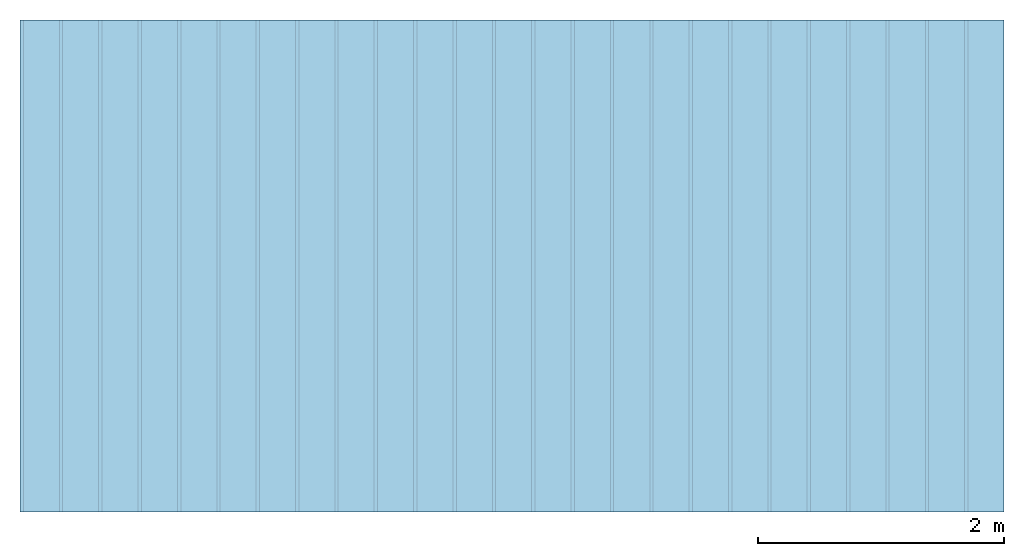
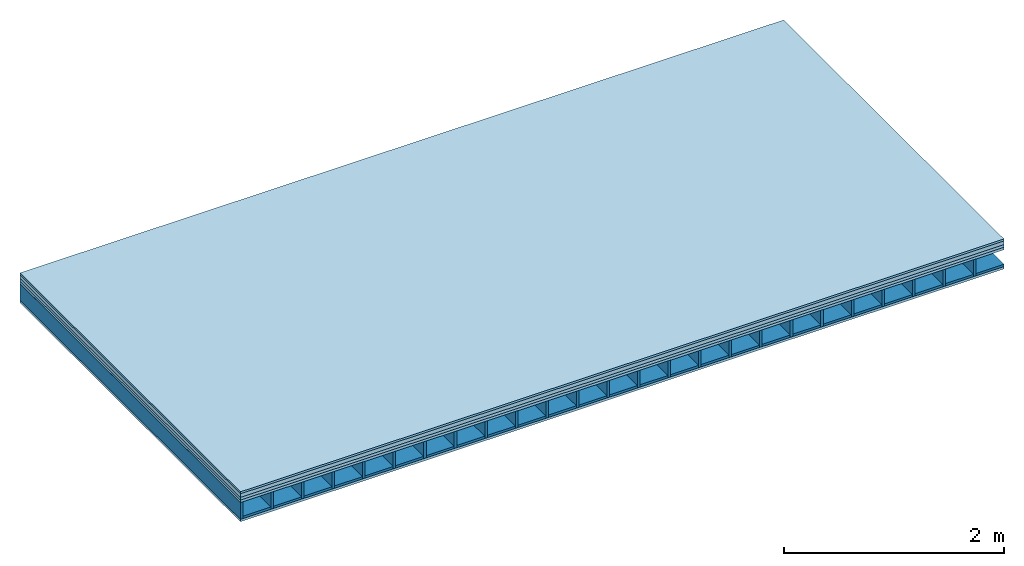
# One storey: 5 plates, 2 members, 1 element without a shape of its own.
"""IFC4 building model written with IfcOpenShell, lengths in metres."""

from ifc_helpers import new_model, si_unit, derived_unit, direction, frame, frame_2d, origin, origin_with_axes, place, context, project, spatial, rectangle, extrude, material, layer, layer_set, type_object, element, aggregate, save


model = new_model("IFC4")

# Units and contexts
plan_context = context("Plan", 3, precision=1e-05, world=origin(), true_north=direction((0.0, 1.0)))
model_context = context("Model", 3, precision=1e-05, world=origin(), true_north=direction((0.0, 1.0)))
ifc_project = project(units=[si_unit("LENGTHUNIT", "METRE"), derived_unit("SOUNDPRESSUREUNIT", [(si_unit("PRESSUREUNIT", "PASCAL", prefix="MICRO"), 0)]), si_unit("ENERGYUNIT", "JOULE", prefix="MEGA"), si_unit("MASSUNIT", "GRAM", prefix="KILO"), derived_unit("THERMALTRANSMITTANCEUNIT", [(si_unit("POWERUNIT", "WATT"), 1), (si_unit("AREAUNIT", "SQUARE_METRE"), -1), (si_unit("THERMODYNAMICTEMPERATUREUNIT", "KELVIN"), -1)]), derived_unit("AREADENSITYUNIT", [(si_unit("MASSUNIT", "GRAM", prefix="KILO"), 1), (si_unit("AREAUNIT", "SQUARE_METRE"), -1)]), derived_unit("USERDEFINED", [(si_unit("ENERGYUNIT", "JOULE", prefix="MEGA"), 1), (si_unit("AREAUNIT", "SQUARE_METRE"), -1)])], contexts=[plan_context, model_context])

# Site, building, storey
site = spatial("IfcSite", under=ifc_project)
building_placement = place(None, origin())
building = spatial("IfcBuilding", under=site, at=building_placement)
storey_placement = place(building_placement, origin())
storey = spatial("IfcBuildingStorey", under=building, at=storey_placement)

# Slab, members, plates
ifc_material_1 = material(Name="OSB/3", Category="07.013")
ifc_layer_1 = layer(ifc_material_1, 0.022, Name="On-material")
ifc_material_2 = material(Name="internal", Category="10.009")
ifc_layer_2 = layer(ifc_material_2, 0.04, Name="Impact sound insulation")
ifc_material_3 = material(Name="with broken")
ifc_layer_3 = layer(ifc_material_3, 0.03, Name="on Supporting structure")
ifc_material_4 = material(Name="3-layer board Spruce Nova Top", Category="07.001")
ifc_layer_4 = layer(ifc_material_4, 0.027, Name="Sub-floor")
ifc_material_5 = material(Name="Rigid, of the art")
ifc_layer_5 = layer(ifc_material_5, 0.0, Name="Bond")
ifc_layer_6 = layer(None, 0.186, Name="Supporting structure")
ifc_layer_7 = layer(ifc_material_5, 0.0, Name="Bond")
ifc_layer_8 = layer(ifc_material_4, 0.027, Name="Lower layer 1")
ifc_layer_set = layer_set([ifc_layer_1, ifc_layer_2, ifc_layer_3, ifc_layer_4, ifc_layer_5, ifc_layer_6, ifc_layer_7, ifc_layer_8])
slab_type = type_object("IfcSlabType", Name="A0016", PredefinedType="NOTDEFINED", material=ifc_layer_set)
slab_placement = place(None, frame((0.0, 0.0, 0.0), z_axis=(0.0, 0.0, -1.0), x_axis=(1.0, 0.0, 0.0)))
slab = element("IfcSlab", 1, at=slab_placement, inside=storey, type_object=slab_type, material=ifc_layer_set, Name="Slab #1")
ifc_material_6 = material()
member_1_placement = place(slab_placement, origin())
member_1 = element("IfcMember", 2, at=member_1_placement, material=ifc_material_6, Name="Supporting structure", context=plan_context, shape_type="SweptSolid", body=[
    extrude(rectangle(XDim=0.027, YDim=0.186, at=frame_2d((0.0135, 0.093), x_axis=(1.0, 0.0))), frame((0.0, 4.0, 0.119), z_axis=(0.0, -1.0, 0.0), x_axis=(1.0, 0.0, 0.0)), (0.0, 0.0, 1.0), 4.0),
    extrude(rectangle(XDim=0.027, YDim=0.186, at=frame_2d((0.0135, 0.093), x_axis=(1.0, 0.0))), frame((0.32, 4.0, 0.119), z_axis=(0.0, -1.0, 0.0), x_axis=(1.0, 0.0, 0.0)), (0.0, 0.0, 1.0), 4.0),
    extrude(rectangle(XDim=0.027, YDim=0.186, at=frame_2d((0.0135, 0.093), x_axis=(1.0, 0.0))), frame((0.64, 4.0, 0.119), z_axis=(0.0, -1.0, 0.0), x_axis=(1.0, 0.0, 0.0)), (0.0, 0.0, 1.0), 4.0),
    extrude(rectangle(XDim=0.027, YDim=0.186, at=frame_2d((0.0135, 0.093), x_axis=(1.0, 0.0))), frame((0.96, 4.0, 0.119), z_axis=(0.0, -1.0, 0.0), x_axis=(1.0, 0.0, 0.0)), (0.0, 0.0, 1.0), 4.0),
    extrude(rectangle(XDim=0.027, YDim=0.186, at=frame_2d((0.0135, 0.093), x_axis=(1.0, 0.0))), frame((1.28, 4.0, 0.119), z_axis=(0.0, -1.0, 0.0), x_axis=(1.0, 0.0, 0.0)), (0.0, 0.0, 1.0), 4.0),
    extrude(rectangle(XDim=0.027, YDim=0.186, at=frame_2d((0.0135, 0.093), x_axis=(1.0, 0.0))), frame((1.6, 4.0, 0.119), z_axis=(0.0, -1.0, 0.0), x_axis=(1.0, 0.0, 0.0)), (0.0, 0.0, 1.0), 4.0),
    extrude(rectangle(XDim=0.027, YDim=0.186, at=frame_2d((0.0135, 0.093), x_axis=(1.0, 0.0))), frame((1.92, 4.0, 0.119), z_axis=(0.0, -1.0, 0.0), x_axis=(1.0, 0.0, 0.0)), (0.0, 0.0, 1.0), 4.0),
    extrude(rectangle(XDim=0.027, YDim=0.186, at=frame_2d((0.0135, 0.093), x_axis=(1.0, 0.0))), frame((2.24, 4.0, 0.119), z_axis=(0.0, -1.0, 0.0), x_axis=(1.0, 0.0, 0.0)), (0.0, 0.0, 1.0), 4.0),
    extrude(rectangle(XDim=0.027, YDim=0.186, at=frame_2d((0.0135, 0.093), x_axis=(1.0, 0.0))), frame((2.56, 4.0, 0.119), z_axis=(0.0, -1.0, 0.0), x_axis=(1.0, 0.0, 0.0)), (0.0, 0.0, 1.0), 4.0),
    extrude(rectangle(XDim=0.027, YDim=0.186, at=frame_2d((0.0135, 0.093), x_axis=(1.0, 0.0))), frame((2.88, 4.0, 0.119), z_axis=(0.0, -1.0, 0.0), x_axis=(1.0, 0.0, 0.0)), (0.0, 0.0, 1.0), 4.0),
    extrude(rectangle(XDim=0.027, YDim=0.186, at=frame_2d((0.0135, 0.093), x_axis=(1.0, 0.0))), frame((3.2, 4.0, 0.119), z_axis=(0.0, -1.0, 0.0), x_axis=(1.0, 0.0, 0.0)), (0.0, 0.0, 1.0), 4.0),
    extrude(rectangle(XDim=0.027, YDim=0.186, at=frame_2d((0.0135, 0.093), x_axis=(1.0, 0.0))), frame((3.52, 4.0, 0.119), z_axis=(0.0, -1.0, 0.0), x_axis=(1.0, 0.0, 0.0)), (0.0, 0.0, 1.0), 4.0),
    extrude(rectangle(XDim=0.027, YDim=0.186, at=frame_2d((0.0135, 0.093), x_axis=(1.0, 0.0))), frame((3.84, 4.0, 0.119), z_axis=(0.0, -1.0, 0.0), x_axis=(1.0, 0.0, 0.0)), (0.0, 0.0, 1.0), 4.0),
    extrude(rectangle(XDim=0.027, YDim=0.186, at=frame_2d((0.0135, 0.093), x_axis=(1.0, 0.0))), frame((4.16, 4.0, 0.119), z_axis=(0.0, -1.0, 0.0), x_axis=(1.0, 0.0, 0.0)), (0.0, 0.0, 1.0), 4.0),
    extrude(rectangle(XDim=0.027, YDim=0.186, at=frame_2d((0.0135, 0.093), x_axis=(1.0, 0.0))), frame((4.48, 4.0, 0.119), z_axis=(0.0, -1.0, 0.0), x_axis=(1.0, 0.0, 0.0)), (0.0, 0.0, 1.0), 4.0),
    extrude(rectangle(XDim=0.027, YDim=0.186, at=frame_2d((0.0135, 0.093), x_axis=(1.0, 0.0))), frame((4.8, 4.0, 0.119), z_axis=(0.0, -1.0, 0.0), x_axis=(1.0, 0.0, 0.0)), (0.0, 0.0, 1.0), 4.0),
    extrude(rectangle(XDim=0.027, YDim=0.186, at=frame_2d((0.0135, 0.093), x_axis=(1.0, 0.0))), frame((5.12, 4.0, 0.119), z_axis=(0.0, -1.0, 0.0), x_axis=(1.0, 0.0, 0.0)), (0.0, 0.0, 1.0), 4.0),
    extrude(rectangle(XDim=0.027, YDim=0.186, at=frame_2d((0.0135, 0.093), x_axis=(1.0, 0.0))), frame((5.44, 4.0, 0.119), z_axis=(0.0, -1.0, 0.0), x_axis=(1.0, 0.0, 0.0)), (0.0, 0.0, 1.0), 4.0),
    extrude(rectangle(XDim=0.027, YDim=0.186, at=frame_2d((0.0135, 0.093), x_axis=(1.0, 0.0))), frame((5.76, 4.0, 0.119), z_axis=(0.0, -1.0, 0.0), x_axis=(1.0, 0.0, 0.0)), (0.0, 0.0, 1.0), 4.0),
    extrude(rectangle(XDim=0.027, YDim=0.186, at=frame_2d((0.0135, 0.093), x_axis=(1.0, 0.0))), frame((6.08, 4.0, 0.119), z_axis=(0.0, -1.0, 0.0), x_axis=(1.0, 0.0, 0.0)), (0.0, 0.0, 1.0), 4.0),
    extrude(rectangle(XDim=0.027, YDim=0.186, at=frame_2d((0.0135, 0.093), x_axis=(1.0, 0.0))), frame((6.4, 4.0, 0.119), z_axis=(0.0, -1.0, 0.0), x_axis=(1.0, 0.0, 0.0)), (0.0, 0.0, 1.0), 4.0),
    extrude(rectangle(XDim=0.027, YDim=0.186, at=frame_2d((0.0135, 0.093), x_axis=(1.0, 0.0))), frame((6.72, 4.0, 0.119), z_axis=(0.0, -1.0, 0.0), x_axis=(1.0, 0.0, 0.0)), (0.0, 0.0, 1.0), 4.0),
    extrude(rectangle(XDim=0.027, YDim=0.186, at=frame_2d((0.0135, 0.093), x_axis=(1.0, 0.0))), frame((7.04, 4.0, 0.119), z_axis=(0.0, -1.0, 0.0), x_axis=(1.0, 0.0, 0.0)), (0.0, 0.0, 1.0), 4.0),
    extrude(rectangle(XDim=0.027, YDim=0.186, at=frame_2d((0.0135, 0.093), x_axis=(1.0, 0.0))), frame((7.36, 4.0, 0.119), z_axis=(0.0, -1.0, 0.0), x_axis=(1.0, 0.0, 0.0)), (0.0, 0.0, 1.0), 4.0),
    extrude(rectangle(XDim=0.027, YDim=0.186, at=frame_2d((0.0135, 0.093), x_axis=(1.0, 0.0))), frame((7.68, 4.0, 0.119), z_axis=(0.0, -1.0, 0.0), x_axis=(1.0, 0.0, 0.0)), (0.0, 0.0, 1.0), 4.0),
])
ifc_material_7 = material(Name="Gravel of lime 3-6 mm")
member_2_placement = place(slab_placement, origin())
member_2 = element("IfcMember", 3, at=member_2_placement, material=ifc_material_7, Name="in supporting structure", context=plan_context, shape_type="SweptSolid", body=[
    extrude(rectangle(XDim=0.293, YDim=0.025, at=frame_2d((0.1465, 0.0125), x_axis=(1.0, 0.0))), frame((0.027, 4.0, 0.28), z_axis=(0.0, -1.0, 0.0), x_axis=(1.0, 0.0, 0.0)), (0.0, 0.0, 1.0), 4.0),
    extrude(rectangle(XDim=0.293, YDim=0.025, at=frame_2d((0.1465, 0.0125), x_axis=(1.0, 0.0))), frame((0.347, 4.0, 0.28), z_axis=(0.0, -1.0, 0.0), x_axis=(1.0, 0.0, 0.0)), (0.0, 0.0, 1.0), 4.0),
    extrude(rectangle(XDim=0.293, YDim=0.025, at=frame_2d((0.1465, 0.0125), x_axis=(1.0, 0.0))), frame((0.667, 4.0, 0.28), z_axis=(0.0, -1.0, 0.0), x_axis=(1.0, 0.0, 0.0)), (0.0, 0.0, 1.0), 4.0),
    extrude(rectangle(XDim=0.293, YDim=0.025, at=frame_2d((0.1465, 0.0125), x_axis=(1.0, 0.0))), frame((0.987, 4.0, 0.28), z_axis=(0.0, -1.0, 0.0), x_axis=(1.0, 0.0, 0.0)), (0.0, 0.0, 1.0), 4.0),
    extrude(rectangle(XDim=0.293, YDim=0.025, at=frame_2d((0.1465, 0.0125), x_axis=(1.0, 0.0))), frame((1.307, 4.0, 0.28), z_axis=(0.0, -1.0, 0.0), x_axis=(1.0, 0.0, 0.0)), (0.0, 0.0, 1.0), 4.0),
    extrude(rectangle(XDim=0.293, YDim=0.025, at=frame_2d((0.1465, 0.0125), x_axis=(1.0, 0.0))), frame((1.627, 4.0, 0.28), z_axis=(0.0, -1.0, 0.0), x_axis=(1.0, 0.0, 0.0)), (0.0, 0.0, 1.0), 4.0),
    extrude(rectangle(XDim=0.293, YDim=0.025, at=frame_2d((0.1465, 0.0125), x_axis=(1.0, 0.0))), frame((1.947, 4.0, 0.28), z_axis=(0.0, -1.0, 0.0), x_axis=(1.0, 0.0, 0.0)), (0.0, 0.0, 1.0), 4.0),
    extrude(rectangle(XDim=0.293, YDim=0.025, at=frame_2d((0.1465, 0.0125), x_axis=(1.0, 0.0))), frame((2.267, 4.0, 0.28), z_axis=(0.0, -1.0, 0.0), x_axis=(1.0, 0.0, 0.0)), (0.0, 0.0, 1.0), 4.0),
    extrude(rectangle(XDim=0.293, YDim=0.025, at=frame_2d((0.1465, 0.0125), x_axis=(1.0, 0.0))), frame((2.587, 4.0, 0.28), z_axis=(0.0, -1.0, 0.0), x_axis=(1.0, 0.0, 0.0)), (0.0, 0.0, 1.0), 4.0),
    extrude(rectangle(XDim=0.293, YDim=0.025, at=frame_2d((0.1465, 0.0125), x_axis=(1.0, 0.0))), frame((2.907, 4.0, 0.28), z_axis=(0.0, -1.0, 0.0), x_axis=(1.0, 0.0, 0.0)), (0.0, 0.0, 1.0), 4.0),
    extrude(rectangle(XDim=0.293, YDim=0.025, at=frame_2d((0.1465, 0.0125), x_axis=(1.0, 0.0))), frame((3.227, 4.0, 0.28), z_axis=(0.0, -1.0, 0.0), x_axis=(1.0, 0.0, 0.0)), (0.0, 0.0, 1.0), 4.0),
    extrude(rectangle(XDim=0.293, YDim=0.025, at=frame_2d((0.1465, 0.0125), x_axis=(1.0, 0.0))), frame((3.547, 4.0, 0.28), z_axis=(0.0, -1.0, 0.0), x_axis=(1.0, 0.0, 0.0)), (0.0, 0.0, 1.0), 4.0),
    extrude(rectangle(XDim=0.293, YDim=0.025, at=frame_2d((0.1465, 0.0125), x_axis=(1.0, 0.0))), frame((3.867, 4.0, 0.28), z_axis=(0.0, -1.0, 0.0), x_axis=(1.0, 0.0, 0.0)), (0.0, 0.0, 1.0), 4.0),
    extrude(rectangle(XDim=0.293, YDim=0.025, at=frame_2d((0.1465, 0.0125), x_axis=(1.0, 0.0))), frame((4.187, 4.0, 0.28), z_axis=(0.0, -1.0, 0.0), x_axis=(1.0, 0.0, 0.0)), (0.0, 0.0, 1.0), 4.0),
    extrude(rectangle(XDim=0.293, YDim=0.025, at=frame_2d((0.1465, 0.0125), x_axis=(1.0, 0.0))), frame((4.507, 4.0, 0.28), z_axis=(0.0, -1.0, 0.0), x_axis=(1.0, 0.0, 0.0)), (0.0, 0.0, 1.0), 4.0),
    extrude(rectangle(XDim=0.293, YDim=0.025, at=frame_2d((0.1465, 0.0125), x_axis=(1.0, 0.0))), frame((4.827, 4.0, 0.28), z_axis=(0.0, -1.0, 0.0), x_axis=(1.0, 0.0, 0.0)), (0.0, 0.0, 1.0), 4.0),
    extrude(rectangle(XDim=0.293, YDim=0.025, at=frame_2d((0.1465, 0.0125), x_axis=(1.0, 0.0))), frame((5.147, 4.0, 0.28), z_axis=(0.0, -1.0, 0.0), x_axis=(1.0, 0.0, 0.0)), (0.0, 0.0, 1.0), 4.0),
    extrude(rectangle(XDim=0.293, YDim=0.025, at=frame_2d((0.1465, 0.0125), x_axis=(1.0, 0.0))), frame((5.467, 4.0, 0.28), z_axis=(0.0, -1.0, 0.0), x_axis=(1.0, 0.0, 0.0)), (0.0, 0.0, 1.0), 4.0),
    extrude(rectangle(XDim=0.293, YDim=0.025, at=frame_2d((0.1465, 0.0125), x_axis=(1.0, 0.0))), frame((5.787, 4.0, 0.28), z_axis=(0.0, -1.0, 0.0), x_axis=(1.0, 0.0, 0.0)), (0.0, 0.0, 1.0), 4.0),
    extrude(rectangle(XDim=0.293, YDim=0.025, at=frame_2d((0.1465, 0.0125), x_axis=(1.0, 0.0))), frame((6.107, 4.0, 0.28), z_axis=(0.0, -1.0, 0.0), x_axis=(1.0, 0.0, 0.0)), (0.0, 0.0, 1.0), 4.0),
    extrude(rectangle(XDim=0.293, YDim=0.025, at=frame_2d((0.1465, 0.0125), x_axis=(1.0, 0.0))), frame((6.427, 4.0, 0.28), z_axis=(0.0, -1.0, 0.0), x_axis=(1.0, 0.0, 0.0)), (0.0, 0.0, 1.0), 4.0),
    extrude(rectangle(XDim=0.293, YDim=0.025, at=frame_2d((0.1465, 0.0125), x_axis=(1.0, 0.0))), frame((6.747, 4.0, 0.28), z_axis=(0.0, -1.0, 0.0), x_axis=(1.0, 0.0, 0.0)), (0.0, 0.0, 1.0), 4.0),
    extrude(rectangle(XDim=0.293, YDim=0.025, at=frame_2d((0.1465, 0.0125), x_axis=(1.0, 0.0))), frame((7.067, 4.0, 0.28), z_axis=(0.0, -1.0, 0.0), x_axis=(1.0, 0.0, 0.0)), (0.0, 0.0, 1.0), 4.0),
    extrude(rectangle(XDim=0.293, YDim=0.025, at=frame_2d((0.1465, 0.0125), x_axis=(1.0, 0.0))), frame((7.387, 4.0, 0.28), z_axis=(0.0, -1.0, 0.0), x_axis=(1.0, 0.0, 0.0)), (0.0, 0.0, 1.0), 4.0),
    extrude(rectangle(XDim=0.293, YDim=0.025, at=frame_2d((0.1465, 0.0125), x_axis=(1.0, 0.0))), frame((7.707, 4.0, 0.28), z_axis=(0.0, -1.0, 0.0), x_axis=(1.0, 0.0, 0.0)), (0.0, 0.0, 1.0), 4.0),
])
plate_1_placement = place(slab_placement, origin())
plate_1 = element("IfcPlate", 4, at=plate_1_placement, material=ifc_material_1, Name="On-material", context=plan_context, shape_type="SweptSolid", body=[
    extrude(rectangle(XDim=8.0, YDim=4.0, at=frame_2d((4.0, 2.0), x_axis=(1.0, 0.0))), origin_with_axes(), (0.0, 0.0, 1.0), 0.022),
])
plate_2_placement = place(slab_placement, origin())
plate_2 = element("IfcPlate", 5, at=plate_2_placement, material=ifc_material_2, Name="Impact sound insulation", context=plan_context, shape_type="SweptSolid", body=[
    extrude(rectangle(XDim=8.0, YDim=4.0, at=frame_2d((4.0, 2.0), x_axis=(1.0, 0.0))), frame((0.0, 0.0, 0.022), z_axis=(0.0, 0.0, 1.0), x_axis=(1.0, 0.0, 0.0)), (0.0, 0.0, 1.0), 0.04),
])
plate_3_placement = place(slab_placement, origin())
plate_3 = element("IfcPlate", 6, at=plate_3_placement, material=ifc_material_3, Name="on Supporting structure", context=plan_context, shape_type="SweptSolid", body=[
    extrude(rectangle(XDim=8.0, YDim=4.0, at=frame_2d((4.0, 2.0), x_axis=(1.0, 0.0))), frame((0.0, 0.0, 0.062), z_axis=(0.0, 0.0, 1.0), x_axis=(1.0, 0.0, 0.0)), (0.0, 0.0, 1.0), 0.03),
])
plate_4_placement = place(slab_placement, origin())
plate_4 = element("IfcPlate", 7, at=plate_4_placement, material=ifc_material_4, Name="Sub-floor", context=plan_context, shape_type="SweptSolid", body=[
    extrude(rectangle(XDim=8.0, YDim=4.0, at=frame_2d((4.0, 2.0), x_axis=(1.0, 0.0))), frame((0.0, 0.0, 0.092), z_axis=(0.0, 0.0, 1.0), x_axis=(1.0, 0.0, 0.0)), (0.0, 0.0, 1.0), 0.027),
])
plate_5_placement = place(slab_placement, origin())
plate_5 = element("IfcPlate", 8, at=plate_5_placement, material=ifc_material_4, Name="Lower layer 1", context=plan_context, shape_type="SweptSolid", body=[
    extrude(rectangle(XDim=8.0, YDim=4.0, at=frame_2d((4.0, 2.0), x_axis=(1.0, 0.0))), frame((0.0, 0.0, 0.305), z_axis=(0.0, 0.0, 1.0), x_axis=(1.0, 0.0, 0.0)), (0.0, 0.0, 1.0), 0.027),
])
aggregate(slab, [plate_1, plate_2, plate_3, plate_4, member_1, member_2, plate_5])

save(model, "model.ifc")
